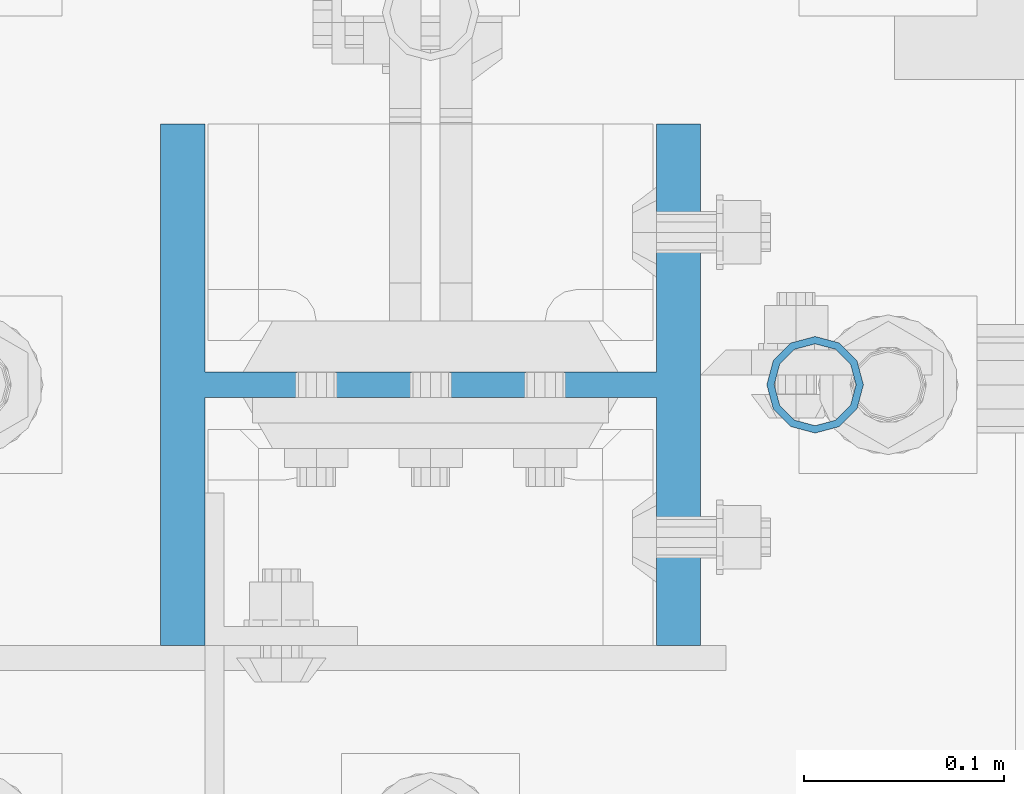
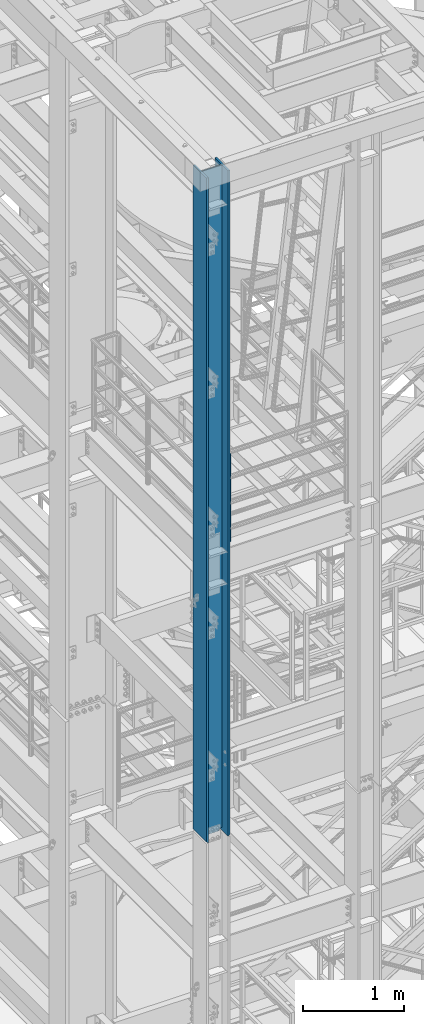
# One storey, part 557 of 1876: 2 columns, 2 elements without a shape of their own.
"""IFC2X3 building model written with IfcOpenShell, lengths in millimetres."""

from ifc_helpers import new_model, si_unit, frame, origin_with_axes, place, context, subcontext, project, spatial, faceted_brep, material, type_object, element, aggregate, save


model = new_model("IFC2X3")

# Units and contexts
model_context = context("Model", 3, precision=1e-05, world=origin_with_axes())
body_context = subcontext(model_context, "Body", "Model", "MODEL_VIEW")
ifc_project = project(units=[si_unit("LENGTHUNIT", "METRE", prefix="MILLI"), si_unit("AREAUNIT", "SQUARE_METRE"), si_unit("VOLUMEUNIT", "CUBIC_METRE"), si_unit("MASSUNIT", "GRAM", prefix="KILO"), si_unit("TIMEUNIT", "SECOND"), si_unit("PLANEANGLEUNIT", "RADIAN"), si_unit("SOLIDANGLEUNIT", "STERADIAN"), si_unit("THERMODYNAMICTEMPERATUREUNIT", "DEGREE_CELSIUS"), si_unit("LUMINOUSINTENSITYUNIT", "LUMEN")], contexts=[model_context])

# Site, building, storey
site_placement = place(None, origin_with_axes())
site = spatial("IfcSite", under=ifc_project, at=site_placement, CompositionType="ELEMENT")
building_placement = place(site_placement, origin_with_axes())
building = spatial("IfcBuilding", under=site, at=building_placement, Name="Undefined", CompositionType="ELEMENT")
storey_placement = place(building_placement, origin_with_axes())
storey = spatial("IfcBuildingStorey", under=building, at=storey_placement, Name="Undefined", CompositionType="ELEMENT", Elevation=0.0)

# Assembly, column
assembly_1_placement = place(storey_placement, origin_with_axes())
assembly_1 = element("IfcElementAssembly", 1, at=assembly_1_placement, inside=storey, Name="RAIL", AssemblyPlace="NOTDEFINED", PredefinedType="RIGID_FRAME")
ifc_material_1 = material()
column_type_1 = type_object("IfcColumnType", Name="PIPE1-1/2SCH40", PredefinedType="NOTDEFINED")
column_1_placement = place(assembly_1_placement, frame((192.0875, -7112.0, 17983.2), z_axis=(0.0, 1.0, 0.0), x_axis=(0.0, 0.0, 1.0)))
column_1 = element("IfcColumn", 2, at=column_1_placement, type_object=column_type_1, material=ifc_material_1, Name="POST", ObjectType="PIPE1-1/2SCH40", context=body_context, shape_type="Brep", body=[
    faceted_brep([(0.0, -20.4469999999999, 0.0), (0.0, -17.7076214311803, 10.2235000000001), (1094.03262143118, -17.7076214311804, 10.2235000000001), (1096.772, -20.447, 0.0), (0.0, -10.2235000000001, 17.7076214311801), (1086.5485, -10.2235, 17.7076214311801), (-1.45519152283669e-11, 0.0, 20.4470000000001), (1076.325, 0.0, 20.4470000000001), (0.0, 10.2235000000001, 17.7076214311801), (1066.1015, 10.2235, 17.7076214311801), (0.0, 17.7076214311803, 10.2235000000001), (1058.61737856882, 17.7076214311804, 10.2235000000001), (0.0, 20.4469999999999, 0.0), (1055.878, 20.447, 0.0), (0.0, 17.7076214311803, -10.2235000000001), (1058.61737856882, 17.7076214311804, -10.2235000000001), (0.0, 10.2235000000001, -17.7076214311801), (1066.1015, 10.2235, -17.7076214311801), (-1.45519152283669e-11, 0.0, -20.4470000000001), (1076.325, 0.0, -20.4470000000001), (0.0, -10.2235000000001, -17.7076214311801), (1086.5485, -10.2235, -17.7076214311801), (0.0, -17.7076214311803, -10.2235000000001), (1094.03262143118, -17.7076214311804, -10.2235000000001), (0.0, -24.1299999999992, 0.0), (0.0, -20.8971929933184, -12.0649999999996), (1097.22219299332, -20.8971929933185, -12.0649999999996), (1100.455, -24.13, 0.0), (0.0, -12.0650000000001, -20.8971929933186), (1088.39, -12.065, -20.8971929933186), (-1.45519152283669e-11, 0.0, -24.130000000001), (1076.325, 0.0, -24.1300000000001), (0.0, 12.0650000000001, -20.8971929933186), (1064.26, 12.065, -20.8971929933186), (0.0, 20.8971929933184, -12.0649999999996), (1055.42780700668, 20.8971929933185, -12.0649999999996), (0.0, 24.1299999999992, 0.0), (1052.195, 24.13, 0.0), (0.0, 20.8971929933184, 12.0649999999996), (1055.42780700668, 20.8971929933185, 12.0649999999996), (0.0, 12.0650000000001, 20.8971929933186), (1064.26, 12.065, 20.8971929933186), (-1.45519152283669e-11, 0.0, 24.130000000001), (1076.325, 0.0, 24.1300000000001), (0.0, -12.0650000000001, 20.8971929933186), (1088.39, -12.065, 20.8971929933186), (0.0, -20.8971929933184, 12.0649999999996), (1097.22219299332, -20.8971929933185, 12.0649999999996)], [[[0, 1, 2, 3]], [[1, 4, 5, 2]], [[4, 6, 7, 5]], [[6, 8, 9, 7]], [[8, 10, 11, 9]], [[10, 12, 13, 11]], [[12, 14, 15, 13]], [[14, 16, 17, 15]], [[16, 18, 19, 17]], [[18, 20, 21, 19]], [[20, 22, 23, 21]], [[22, 0, 3, 23]], [[24, 25, 26, 27]], [[25, 28, 29, 26]], [[28, 30, 31, 29]], [[30, 32, 33, 31]], [[32, 34, 35, 33]], [[34, 36, 37, 35]], [[36, 38, 39, 37]], [[38, 40, 41, 39]], [[40, 42, 43, 41]], [[42, 44, 45, 43]], [[44, 46, 47, 45]], [[46, 24, 27, 47]], [[29, 31, 33, 35, 37, 39, 41, 43, 45, 47, 27, 26], [5, 7, 9, 11, 13, 15, 17, 19, 21, 23, 3, 2]], [[46, 44, 42, 40, 38, 36, 34, 32, 30, 28, 25, 24], [22, 20, 18, 16, 14, 12, 10, 8, 6, 4, 1, 0]]]),
])
aggregate(assembly_1, [column_1])

assembly_2_placement = place(storey_placement, origin_with_axes())
assembly_2 = element("IfcElementAssembly", 3, at=assembly_2_placement, inside=storey, Name="COLUMN", AssemblyPlace="NOTDEFINED", PredefinedType="RIGID_FRAME")
ifc_material_2 = material(Name="STEEL/A992")
column_type_2 = type_object("IfcColumnType", Name="W10X77", PredefinedType="NOTDEFINED")
column_2_placement = place(assembly_2_placement, frame((0.0, -7112.0, 14528.8), z_axis=(-1.0, 0.0, 0.0), x_axis=(0.0, 0.0, 1.0)))
column_2 = element("IfcColumn", 4, at=column_2_placement, type_object=column_type_2, material=ifc_material_2, Name="COLUMN", ObjectType="W10X77", context=body_context, shape_type="Brep", body=[
    faceted_brep([(15.8749999999945, 6.35000000000036, 82.471111788822), (15.8749999999945, 6.35000000000036, -82.471111788822), (6.35000000000036, -3.17500029428084, -80.9625), (6.35000000000036, -3.17500029428084, 80.9625), (8026.39999999999, 130.175, -134.9375), (8026.39999999999, -130.175, -134.9375), (25.4000000342548, -130.175, -134.9375), (25.4000000342548, 130.175, -134.9375), (8026.39999999999, -130.175, -112.7125), (38.1000000342628, -130.175, -112.7125), (6.35000000000036, -130.175, -112.7125), (6.35000000000036, -130.175, -115.887499965744), (38.1000000342628, -6.35000000000036, -112.7125), (6.35000000000036, -6.35000000000036, -112.7125), (8026.39999999999, -6.35000000000036, -112.7125), (6.35000000000036, -130.175, 112.7125), (38.1000000342628, -130.175, 112.7125), (8026.39999999999, -130.175, 112.7125), (8026.39999999999, -130.175, 134.9375), (25.4000000342548, -130.175, 134.9375), (6.35000000000036, -130.175, 115.887499965744), (8026.39999999999, 130.175, 134.9375), (25.4000000342548, 130.175, 134.9375), (6.35000000000036, 130.175, 115.887499965744), (8026.39999999999, 130.175, 112.7125), (38.1000000342628, 130.175, 112.7125), (6.35000000000036, 130.175, 112.7125), (6.35000000000036, -6.35000000000036, 112.7125), (6.35000000000036, 6.35000000000036, 112.7125), (6.35000000000036, -3.17500029428084, 112.7125), (38.1000000342628, -6.35000000000036, 112.7125), (8026.39999999999, -6.35000000000036, 112.7125), (36.5460444266337, -6.35000000000036, 102.901210428595), (32.0362896056668, -6.35000000000036, 94.050318239714), (25.0121817945492, -6.35000000000036, 87.0262104285954), (16.1612896056668, -6.35000000000036, 82.5164556076289), (6.35000000000036, -6.35000000000036, 80.9625), (6.35000000000036, -6.35000000000036, -80.9625), (16.1612896056668, -6.35000000000036, -82.5164556076289), (25.0121817945492, -6.35000000000036, -87.0262104285954), (32.0362896056668, -6.35000000000036, -94.050318239714), (36.5460444266337, -6.35000000000036, -102.901210428595), (16.1612896056668, 6.35000000000036, -82.5164556076289), (25.0121817945492, 6.35000000000036, -87.0262104285954), (32.0362896056668, 6.35000000000036, -94.050318239714), (36.5460444266337, 6.35000000000036, -102.901210428595), (38.1000000342628, 6.35000000000036, -112.7125), (38.1000000342628, 130.175, -112.7125), (6.35000000000036, 130.175, -112.7125), (6.35000000000036, 6.35000000000036, -112.7125), (15.8749999999945, 6.35000000000036, -112.7125), (8026.39999999999, 6.35000000000036, -112.7125), (8026.39999999999, 130.175, -112.7125), (6.35000000000036, -3.17500029428084, -112.7125), (6.35000000000036, 130.175, -115.887499965744), (8026.39999999999, 6.35000000000036, 112.7125), (38.1000000342628, 6.35000000000036, 112.7125), (15.8749999999945, 6.35000000000036, 112.7125), (36.5460444266337, 6.35000000000036, 102.901210428595), (32.0362896056668, 6.35000000000036, 94.050318239714), (25.0121817945492, 6.35000000000036, 87.0262104285954), (16.1612896056668, 6.35000000000036, 82.5164556076289)], [[[0, 1, 2, 3]], [[4, 5, 6, 7]], [[5, 8, 9, 10, 11, 6]], [[12, 13, 10, 9, 8, 14]], [[15, 16, 17, 18, 19, 20]], [[18, 21, 22, 19]], [[19, 22, 23, 20]], [[21, 24, 25, 26, 23, 22]], [[27, 15, 20, 23, 26, 28, 29]], [[16, 15, 27, 30, 31, 17]], [[14, 31, 30, 32, 33, 34, 35, 36, 37, 38, 39, 40, 41, 12]], [[38, 42, 43, 39]], [[39, 43, 44, 40]], [[40, 44, 45, 41]], [[41, 45, 46, 12]], [[47, 48, 49, 50, 46, 51, 52]], [[12, 46, 50, 49, 53, 13]], [[49, 48, 54, 11, 10, 13, 53]], [[6, 11, 54, 7]], [[48, 47, 52, 4, 7, 54]], [[51, 55, 24, 21, 18, 17, 31, 14, 8, 5, 4, 52]], [[56, 57, 28, 26, 25, 24, 55]], [[27, 29, 28, 57, 56, 30]], [[30, 56, 58, 32]], [[32, 58, 59, 33]], [[33, 59, 60, 34]], [[34, 60, 61, 35]], [[36, 35, 61, 0, 3]], [[37, 36, 3, 2]], [[42, 38, 37, 2, 1]], [[61, 60, 59, 58, 56, 55, 51, 46, 45, 44, 43, 42, 1, 0]]]),
])
aggregate(assembly_2, [column_2])

save(model, "model.ifc")
